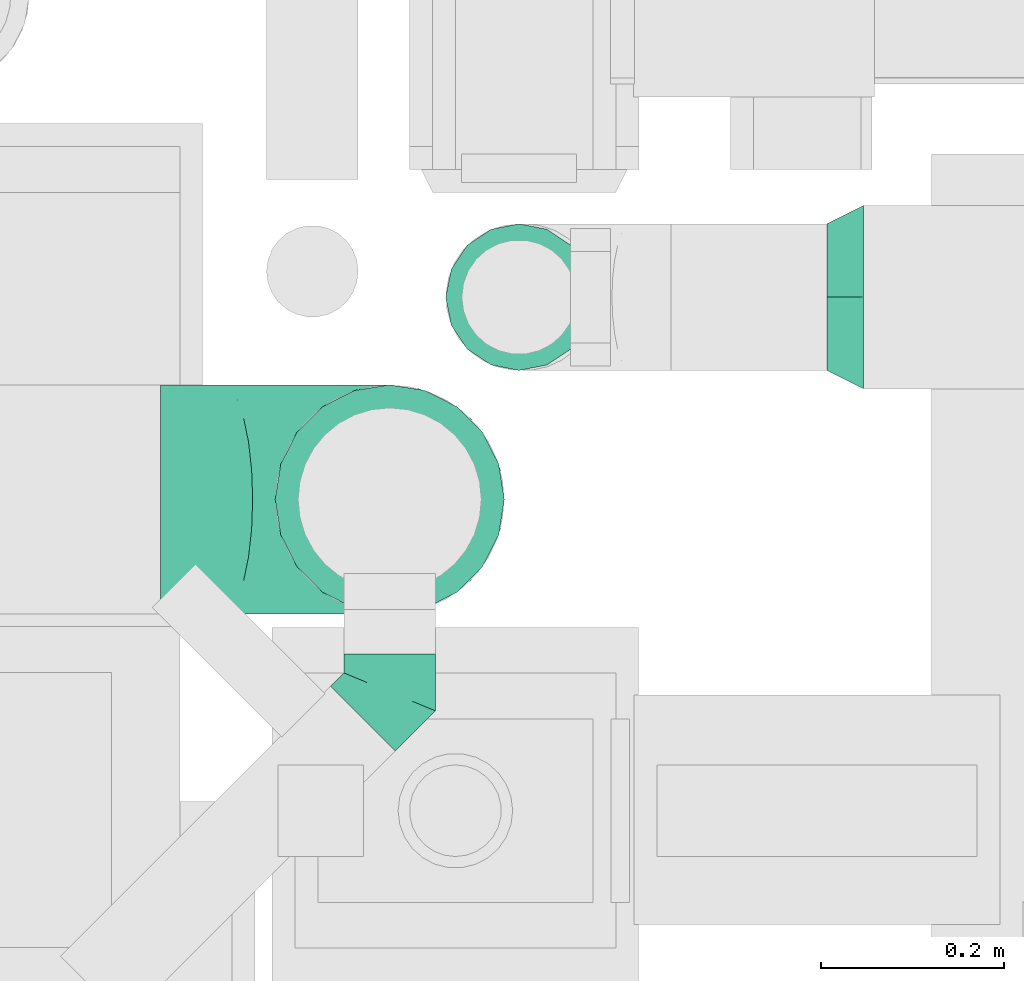
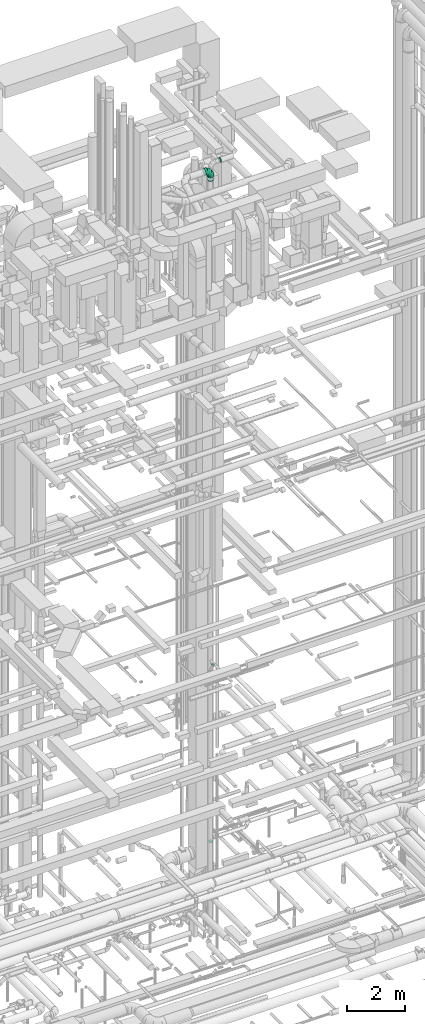
# One storey, part 238 of 337: 5 flow fittings.
"""IFC2X3 building model written with IfcOpenShell, lengths in millimetres."""

import ifcopenshell
import ifcopenshell.guid

model = None  # the IFC model being written
_history = None  # IfcOwnerHistory: only IFC2X3 demands one
_inside = {}  # id of a spatial element -> (the spatial element, [elements in it])
_under = {}  # id of a project, library or spatial element -> (it, [spatial elements below it])
_declared = {}  # id of a project -> (the project, [libraries it declares])
_typed = {}  # id of a type object -> (the type object, [elements of that type])
_made_of = {}  # id of a material, layer set ... -> (it, [elements and type objects made of it])


def new_model(schema):
    """Start an empty IFC model of exactly this schema.

    Asked for "IFC4X3", IfcOpenShell would pick the latest addendum, in which some entities
    have other attributes; the version numbers below select the first issue.
    IFC2X3 requires an IfcOwnerHistory on every rooted entity: one is made here for all.
    """
    global model, _history
    if schema == "IFC4X3":
        model = ifcopenshell.file(schema_version=(4, 3, 0, 0))
    else:
        model = ifcopenshell.file(schema=schema)
    _inside.clear()
    _under.clear()
    _declared.clear()
    _typed.clear()
    _made_of.clear()
    _history = None
    if model.schema == "IFC2X3":
        org = make("IfcOrganization", Name="unknown")
        user = make(
            "IfcPersonAndOrganization",
            ThePerson=make("IfcPerson", FamilyName="unknown"),
            TheOrganization=org,
        )
        app = make(
            "IfcApplication",
            ApplicationDeveloper=org,
            Version="unknown",
            ApplicationFullName="unknown",
            ApplicationIdentifier="unknown",
        )
        _history = make(
            "IfcOwnerHistory",
            OwningUser=user,
            OwningApplication=app,
            ChangeAction="ADDED",
            CreationDate=0,
        )
    return model


def make(cls, **values):
    """One entity of the class cls with the attributes given. An attribute that is None is left unset."""
    return model.create_entity(
        cls, **{name: value for name, value in values.items() if value is not None}
    )


def entity(cls, *values):
    """Any entity or typed value of the class cls, its attributes in the order of the schema. None: left unset."""
    e = model.create_entity(cls)
    for i, value in enumerate(values):
        if value is not None:
            e[i] = value
    return e


def rooted(cls, **values):
    """An entity with a GlobalId (a new one), such as an element, a storey or a relation."""
    return make(cls, GlobalId=ifcopenshell.guid.new(), OwnerHistory=_history, **values)


def si_unit(unit_type, name, prefix=None):
    """IfcSIUnit, for example si_unit("LENGTHUNIT", "METRE", prefix="MILLI")."""
    return make("IfcSIUnit", UnitType=unit_type, Prefix=prefix, Name=name)


def converted_unit(unit_type, name, factor, base, dimensions=None, offset=None):
    """IfcConversionBasedUnit, such as the inch: factor (a typed value) times the base unit."""
    return make(
        "IfcConversionBasedUnit"
        if offset is None
        else "IfcConversionBasedUnitWithOffset",
        ConversionOffset=offset,
        Dimensions=None
        if dimensions is None
        else entity("IfcDimensionalExponents", *dimensions),
        UnitType=unit_type,
        Name=name,
        ConversionFactor=make(
            "IfcMeasureWithUnit", ValueComponent=factor, UnitComponent=base
        ),
    )


def derived_unit(unit_type, elements):
    """IfcDerivedUnit: a product of units, each with its exponent."""
    return make(
        "IfcDerivedUnit",
        Elements=[
            make("IfcDerivedUnitElement", Unit=unit, Exponent=power)
            for unit, power in elements
        ],
        UnitType=unit_type,
    )


def assignment(units):
    """IfcUnitAssignment: the units of a project."""
    return None if units is None else make("IfcUnitAssignment", Units=units)


def point(xyz):
    """IfcCartesianPoint."""
    return None if xyz is None else make("IfcCartesianPoint", Coordinates=xyz)


def direction(xyz):
    """IfcDirection."""
    return None if xyz is None else make("IfcDirection", DirectionRatios=xyz)


def frame(location, z_axis=None, x_axis=None):
    """IfcAxis2Placement3D, a coordinate frame: its origin and axes. An axis left out is left unset."""
    return make(
        "IfcAxis2Placement3D",
        Location=point(location),
        Axis=direction(z_axis),
        RefDirection=direction(x_axis),
    )


def origin():
    """The frame at (0, 0, 0) with its axes left unset."""
    return frame((0.0, 0.0, 0.0))


def place(relative_to, where):
    """IfcLocalPlacement: puts the frame where relative to a parent placement (None: the world)."""
    return make(
        "IfcLocalPlacement", PlacementRelTo=relative_to, RelativePlacement=where
    )


def context(
    kind, dimensions, precision=None, world=None, true_north=None, identifier=None
):
    """IfcGeometricRepresentationContext, for example the 3D "Model" context."""
    return make(
        "IfcGeometricRepresentationContext",
        ContextIdentifier=identifier,
        ContextType=kind,
        CoordinateSpaceDimension=dimensions,
        Precision=precision,
        WorldCoordinateSystem=world,
        TrueNorth=true_north,
    )


def subcontext(parent, identifier, kind, view, scale=None):
    """IfcGeometricRepresentationSubContext, for example "Body" below "Model"."""
    return make(
        "IfcGeometricRepresentationSubContext",
        ContextIdentifier=identifier,
        ContextType=kind,
        ParentContext=parent,
        TargetScale=scale,
        TargetView=view,
    )


def project(units=None, contexts=None):
    """IfcProject with its units and contexts."""
    return rooted(
        "IfcProject",
        Name="project",
        RepresentationContexts=contexts,
        UnitsInContext=assignment(units),
    )


def spatial(cls, under=None, at=None, **own):
    """A site, building, storey or space (cls), placed at a placement, below another one or the project."""
    s = rooted(cls, ObjectPlacement=at, **own)
    if under is not None:
        _under.setdefault(under.id(), (under, []))[1].append(s)
    return s


def faces_of(points, faces, orient=None, outer=None):
    """IfcFace entities. A face is a list of loops; a loop is a list of indices into points, from 0.

    orient and outer hold one flag for each loop. By default every Orientation is true, the
    first loop of a face is its IfcFaceOuterBound and the others are IfcFaceBound.
    """
    made = []
    for i, loops in enumerate(faces):
        bounds = []
        for j, loop in enumerate(loops):
            is_outer = j == 0 if outer is None else outer[i][j]
            bounds.append(
                make(
                    "IfcFaceOuterBound" if is_outer else "IfcFaceBound",
                    Bound=make("IfcPolyLoop", Polygon=[points[k] for k in loop]),
                    Orientation=True if orient is None else orient[i][j],
                )
            )
        made.append(make("IfcFace", Bounds=bounds))
    return made


def faceted_brep(points, faces, orient=None, outer=None, voids=None):
    """IfcFacetedBrep: a solid bounded by flat faces; with voids (closed shells), ...WithVoids."""
    shared = [point(p) for p in points]
    hull = make("IfcClosedShell", CfsFaces=faces_of(shared, faces, orient, outer))
    if voids is None:
        return make("IfcFacetedBrep", Outer=hull)
    return make(
        "IfcFacetedBrepWithVoids",
        Outer=hull,
        Voids=[
            make(cls, CfsFaces=faces_of(shared, fs, o, b)) for cls, fs, o, b in voids
        ],
    )


def shape(context_of_items, identifier, shape_type, items):
    """IfcShapeRepresentation: the items that make up one representation, for example the "Body"."""
    return make(
        "IfcShapeRepresentation",
        ContextOfItems=context_of_items,
        RepresentationIdentifier=identifier,
        RepresentationType=shape_type,
        Items=items,
    )


def source(mapping_origin, context_of_items, identifier, shape_type, items):
    """IfcRepresentationMap: a shape defined once, which mapped items show again and again."""
    return make(
        "IfcRepresentationMap",
        MappingOrigin=mapping_origin,
        MappedRepresentation=shape(context_of_items, identifier, shape_type, items),
    )


def transform(
    local_origin,
    x_axis=None,
    y_axis=None,
    z_axis=None,
    scale=None,
    scale2=None,
    scale3=None,
    uniform=True,
):
    """IfcCartesianTransformationOperator3D, or its non-uniform kind. x_axis, y_axis, z_axis: its Axis1, 2, 3."""
    if uniform:
        return make(
            "IfcCartesianTransformationOperator3D",
            Axis1=direction(x_axis),
            Axis2=direction(y_axis),
            LocalOrigin=point(local_origin),
            Scale=scale,
            Axis3=direction(z_axis),
        )
    return make(
        "IfcCartesianTransformationOperator3DnonUniform",
        Axis1=direction(x_axis),
        Axis2=direction(y_axis),
        LocalOrigin=point(local_origin),
        Scale=scale,
        Axis3=direction(z_axis),
        Scale2=scale2,
        Scale3=scale3,
    )


def mapped(mapping_source, mapping_target):
    """IfcMappedItem: shows the shape of a source again, moved by a transform."""
    return make(
        "IfcMappedItem", MappingSource=mapping_source, MappingTarget=mapping_target
    )


def material(Name=None, Category=None):
    """IfcMaterial."""
    return make("IfcMaterial", Name=Name, Category=Category)


def made_of(thing, what):
    """Note that an element or type object is made of a material, layer set ...; save() writes the relation."""
    if what is not None:
        _made_of.setdefault(what.id(), (what, []))[1].append(thing)
    return thing


def type_object(cls, material=None, **own):
    """A type object (cls), such as IfcWallType, which elements share."""
    return made_of(rooted(cls, **own), material)


def type_shapes(of_type, sources):
    """Give a type object the sources (RepresentationMaps) that its elements show as mapped items."""
    of_type.RepresentationMaps = sources


def element(
    cls,
    number,
    at=None,
    inside=None,
    cuts=None,
    type_object=None,
    material=None,
    context=None,
    identifier="Body",
    shape_type=None,
    held_by="IfcProductDefinitionShape",
    body=None,
    shapes=None,
    **own,
):
    """One element of the class cls, such as IfcWall. Its Tag is "e" and its number.

    at: its placement. inside: the storey or other place that contains it. cuts: it is an
    opening in that element (IfcRelVoidsElement). A single representation is given by context,
    identifier, shape_type and body (its items); several are given by shapes. held_by: the class
    of the entity that holds the representations. save() writes the other relations.
    """
    e = rooted(cls, Tag="e%d" % number, ObjectPlacement=at, **own)
    if body is not None:
        shapes = [shape(context, identifier, shape_type, body)]
    if shapes is not None:
        e.Representation = make(held_by, Representations=shapes)
    if inside is not None:
        _inside.setdefault(inside.id(), (inside, []))[1].append(e)
    if cuts is not None:
        rooted(
            "IfcRelVoidsElement", RelatingBuildingElement=cuts, RelatedOpeningElement=e
        )
    if type_object is not None:
        _typed.setdefault(type_object.id(), (type_object, []))[1].append(e)
    return made_of(e, material)


def aggregate(whole, parts):
    """IfcRelAggregates: a whole, such as a stair, and the parts it consists of."""
    return rooted("IfcRelAggregates", RelatingObject=whole, RelatedObjects=parts)


def save(model, path):
    """Write the relations noted so far, then the file.

    IfcRelAggregates (storeys below a building ...), IfcRelContainedInSpatialStructure (elements
    in a storey), IfcRelDefinesByType, IfcRelAssociatesMaterial and IfcRelDeclares: one each for
    every whole, place, type object, material and project.
    """
    for whole, parts in _under.values():
        aggregate(whole, parts)
    for where, things in _inside.values():
        rooted(
            "IfcRelContainedInSpatialStructure",
            RelatedElements=things,
            RelatingStructure=where,
        )
    for kind, things in _typed.values():
        rooted("IfcRelDefinesByType", RelatedObjects=things, RelatingType=kind)
    for what, things in _made_of.values():
        rooted("IfcRelAssociatesMaterial", RelatedObjects=things, RelatingMaterial=what)
    for by, libraries in _declared.values():
        rooted("IfcRelDeclares", RelatingContext=by, RelatedDefinitions=libraries)
    model.write(path)


model = new_model("IFC2X3")

# Units and contexts
model_context = context("Model", 3, precision=0.01, world=origin(), true_north=direction((6.12303176911189e-17, 1.0)))
body_context = subcontext(model_context, "Body", "Model", "MODEL_VIEW")
ifc_project = project(units=[si_unit("LENGTHUNIT", "METRE", prefix="MILLI"), si_unit("AREAUNIT", "SQUARE_METRE"), si_unit("VOLUMEUNIT", "CUBIC_METRE"), converted_unit("PLANEANGLEUNIT", "DEGREE", entity("IfcRatioMeasure", 0.0174532925199433), si_unit("PLANEANGLEUNIT", "RADIAN"), dimensions=[0, 0, 0, 0, 0, 0, 0]), si_unit("MASSUNIT", "GRAM", prefix="KILO"), derived_unit("MASSDENSITYUNIT", [(si_unit("MASSUNIT", "GRAM", prefix="KILO"), 1), (si_unit("LENGTHUNIT", "METRE"), -3)]), derived_unit("MOMENTOFINERTIAUNIT", [(si_unit("LENGTHUNIT", "METRE"), 4)]), si_unit("TIMEUNIT", "SECOND"), si_unit("FREQUENCYUNIT", "HERTZ"), si_unit("THERMODYNAMICTEMPERATUREUNIT", "DEGREE_CELSIUS"), derived_unit("THERMALTRANSMITTANCEUNIT", [(si_unit("MASSUNIT", "GRAM", prefix="KILO"), 1), (si_unit("THERMODYNAMICTEMPERATUREUNIT", "KELVIN"), -1), (si_unit("TIMEUNIT", "SECOND"), -3)]), derived_unit("VOLUMETRICFLOWRATEUNIT", [(si_unit("LENGTHUNIT", "METRE"), 3), (si_unit("TIMEUNIT", "SECOND"), -1)]), derived_unit("MASSFLOWRATEUNIT", [(si_unit("MASSUNIT", "GRAM", prefix="KILO"), 1), (si_unit("TIMEUNIT", "SECOND"), -1)]), derived_unit("ROTATIONALFREQUENCYUNIT", [(si_unit("TIMEUNIT", "SECOND"), -1)]), si_unit("ELECTRICCURRENTUNIT", "AMPERE"), si_unit("ELECTRICVOLTAGEUNIT", "VOLT"), si_unit("POWERUNIT", "WATT"), si_unit("FORCEUNIT", "NEWTON", prefix="KILO"), si_unit("ILLUMINANCEUNIT", "LUX"), si_unit("LUMINOUSFLUXUNIT", "LUMEN"), si_unit("LUMINOUSINTENSITYUNIT", "CANDELA"), derived_unit("USERDEFINED", [(si_unit("MASSUNIT", "GRAM", prefix="KILO"), -1), (si_unit("LENGTHUNIT", "METRE"), -2), (si_unit("TIMEUNIT", "SECOND"), 3), (si_unit("LUMINOUSFLUXUNIT", "LUMEN"), 1)]), derived_unit("LINEARVELOCITYUNIT", [(si_unit("LENGTHUNIT", "METRE"), 1), (si_unit("TIMEUNIT", "SECOND"), -1)]), si_unit("PRESSUREUNIT", "PASCAL"), derived_unit("USERDEFINED", [(si_unit("LENGTHUNIT", "METRE"), -2), (si_unit("MASSUNIT", "GRAM", prefix="KILO"), 1), (si_unit("TIMEUNIT", "SECOND"), -2)]), derived_unit("LINEARFORCEUNIT", [(si_unit("MASSUNIT", "GRAM", prefix="KILO"), 1), (si_unit("LENGTHUNIT", "METRE"), 1), (si_unit("TIMEUNIT", "SECOND"), -2), (si_unit("LENGTHUNIT", "METRE"), -1)]), derived_unit("PLANARFORCEUNIT", [(si_unit("MASSUNIT", "GRAM", prefix="KILO"), 1), (si_unit("LENGTHUNIT", "METRE"), 1), (si_unit("TIMEUNIT", "SECOND"), -2), (si_unit("LENGTHUNIT", "METRE"), -2)])], contexts=[model_context])

# Site, building, storey
site_placement = place(None, origin())
site = spatial("IfcSite", under=ifc_project, at=site_placement, CompositionType="ELEMENT")
building_placement = place(site_placement, origin())
building = spatial("IfcBuilding", under=site, at=building_placement, CompositionType="ELEMENT")
storey_placement = place(building_placement, origin())
storey = spatial("IfcBuildingStorey", under=building, at=storey_placement, CompositionType="ELEMENT", Elevation=0.0)

# Flow fittings
ifc_material = material()
duct_fitting_type_1 = type_object("IfcDuctFittingType", PredefinedType="NOTDEFINED", material=ifc_material)
shared_shape_1 = source(origin(), body_context, "Body", "Brep", [
    faceted_brep([(40.0, -58.78, -80.9), (40.0, -30.9, -95.11), (40.0, 0.0, -100.0), (40.0, 30.9, -95.11), (40.0, 58.78, -80.9), (40.0, 80.9, -58.78), (40.0, 95.11, -30.9), (40.0, 100.0, 0.0), (40.0, 95.11, 30.9), (40.0, 80.9, 58.78), (40.0, 58.78, 80.9), (40.0, 30.9, 95.11), (40.0, 0.0, 100.0), (40.0, -30.9, 95.11), (40.0, -58.78, 80.9), (40.0, -80.9, 58.78), (40.0, -95.11, 30.9), (40.0, -100.0, 0.0), (40.0, -95.11, -30.9), (40.0, -80.9, -58.78), (0.0, -30.61, -73.91), (0.0, -43.59, -65.24), (0.0, -56.57, -56.57), (0.0, -65.24, -43.59), (0.0, -73.91, -30.61), (0.0, -76.96, -15.31), (0.0, -80.0, 0.0), (0.0, -76.96, 15.31), (0.0, -73.91, 30.61), (0.0, -65.24, 43.59), (0.0, -56.57, 56.57), (0.0, -43.59, 65.24), (0.0, -30.61, 73.91), (0.0, -15.31, 76.96), (0.0, 0.0, 80.0), (0.0, 15.31, 76.96), (0.0, 30.61, 73.91), (0.0, 43.59, 65.24), (0.0, 56.57, 56.57), (0.0, 65.24, 43.59), (0.0, 73.91, 30.61), (0.0, 76.96, 15.31), (0.0, 80.0, 0.0), (0.0, 76.96, -15.31), (0.0, 73.91, -30.61), (0.0, 65.24, -43.59), (0.0, 56.57, -56.57), (0.0, 43.59, -65.24), (0.0, 30.61, -73.91), (0.0, 15.31, -76.96), (0.0, 0.0, -80.0), (0.0, -15.31, -76.96)], [[[0, 1, 2, 3, 4, 5, 6, 7, 8, 9, 10, 11, 12, 13, 14, 15, 16, 17, 18, 19]], [[20, 21, 22, 23, 24, 25, 26, 27, 28, 29, 30, 31, 32, 33, 34, 35, 36, 37, 38, 39, 40, 41, 42, 43, 44, 45, 46, 47, 48, 49, 50, 51]], [[7, 41, 8]], [[40, 9, 8]], [[10, 38, 37, 36]], [[39, 38, 9, 40]], [[11, 36, 35]], [[34, 12, 35]], [[41, 40, 8]], [[10, 36, 11]], [[35, 12, 11]], [[41, 7, 42]], [[38, 10, 9]], [[12, 33, 13]], [[32, 14, 13]], [[15, 30, 29, 28]], [[31, 30, 14, 32]], [[16, 28, 27]], [[26, 17, 27]], [[33, 32, 13]], [[15, 28, 16]], [[27, 17, 16]], [[33, 12, 34]], [[30, 15, 14]], [[17, 25, 18]], [[24, 19, 18]], [[0, 22, 21, 20]], [[23, 22, 19, 24]], [[1, 20, 51]], [[50, 2, 51]], [[25, 24, 18]], [[0, 20, 1]], [[51, 2, 1]], [[25, 17, 26]], [[22, 0, 19]], [[2, 49, 3]], [[48, 4, 3]], [[5, 46, 45, 44]], [[47, 46, 4, 48]], [[6, 44, 43]], [[42, 7, 43]], [[49, 48, 3]], [[5, 44, 6]], [[43, 7, 6]], [[49, 2, 50]], [[46, 5, 4]]]),
])
type_shapes(duct_fitting_type_1, [shared_shape_1])
flow_fitting_1_placement = place(storey_placement, frame((59885.7, 11524.89, 31800.0)))
element("IfcFlowFitting", 1, at=flow_fitting_1_placement, inside=storey, type_object=duct_fitting_type_1, material=ifc_material, context=body_context, shape_type="MappedRepresentation", body=[
    mapped(shared_shape_1, transform((0.0, 0.0, 0.0), scale=1.0)),
])
duct_fitting_type_2 = type_object("IfcDuctFittingType", PredefinedType="NOTDEFINED", material=ifc_material)
shared_shape_2 = source(origin(), body_context, "Body", "Brep", [
    faceted_brep([(-250.0, 0.0, -125.0), (-250.0, -32.35, -120.74), (-250.0, -62.5, -108.25), (-250.0, -88.39, -88.39), (-250.0, -108.25, -62.5), (-250.0, -120.74, -32.35), (-250.0, -125.0, 0.0), (-250.0, -120.74, 32.35), (-250.0, -108.25, 62.5), (-250.0, -88.39, 88.39), (-250.0, -62.5, 108.25), (-250.0, -32.35, 120.74), (-250.0, 0.0, 125.0), (-250.0, 32.35, 120.74), (-250.0, 62.5, 108.25), (-250.0, 88.39, 88.39), (-250.0, 108.25, 62.5), (-250.0, 120.74, 32.35), (-250.0, 125.0, 0.0), (-250.0, 120.74, -32.35), (-250.0, 108.25, -62.5), (-250.0, 88.39, -88.39), (-250.0, 62.5, -108.25), (-250.0, 32.35, -120.74), (-191.68, 32.35, 120.74), (-199.76, 62.5, 108.25), (-183.01, 0.0, 125.0), (-206.7, 88.39, 88.39), (-215.37, 120.74, 32.35), (-216.51, 125.0, 0.0), (-212.02, 108.25, 62.5), (-212.02, 108.25, -62.5), (-206.7, 88.39, -88.39), (-215.37, 120.74, -32.35), (-191.68, 32.35, -120.74), (-183.01, 0.0, -125.0), (-199.76, 62.5, -108.25), (-174.34, -32.35, -120.74), (-166.27, -62.5, -108.25), (-159.33, -88.39, -88.39), (-154.01, -108.25, -62.5), (-150.66, -120.74, -32.35), (-149.52, -125.0, 0.0), (-150.66, -120.74, 32.35), (-154.01, -108.25, 62.5), (-159.33, -88.39, 88.39), (-166.27, -62.5, 108.25), (-174.34, -32.35, 120.74), (-90.67, 90.67, 120.74), (-112.74, 112.74, 108.25), (-66.99, 66.99, 125.0), (-131.69, 131.69, 88.39), (-146.23, 146.23, 62.5), (-155.38, 155.38, 32.35), (-158.49, 158.49, 0.0), (-155.38, 155.38, -32.35), (-146.23, 146.23, -62.5), (-131.69, 131.69, -88.39), (-90.67, 90.67, -120.74), (-66.99, 66.99, -125.0), (-112.74, 112.74, -108.25), (-43.3, 43.3, -120.74), (-21.23, 21.23, -108.25), (-2.28, 2.28, -88.39), (12.26, -12.26, -62.5), (21.4, -21.4, -32.35), (24.52, -24.52, 0.0), (21.4, -21.4, 32.35), (12.26, -12.26, 62.5), (-2.28, 2.28, 88.39), (-21.23, 21.23, 108.25), (-43.3, 43.3, 120.74), (-32.35, 191.68, 120.74), (-62.5, 199.76, 108.25), (0.0, 183.01, 125.0), (-88.39, 206.7, 88.39), (-108.25, 212.02, 62.5), (-120.74, 215.37, 32.35), (-125.0, 216.51, 0.0), (-120.74, 215.37, -32.35), (-108.25, 212.02, -62.5), (-88.39, 206.7, -88.39), (-32.35, 191.68, -120.74), (0.0, 183.01, -125.0), (-62.5, 199.76, -108.25), (32.35, 174.34, -120.74), (62.5, 166.27, -108.25), (88.39, 159.33, -88.39), (108.25, 154.01, -62.5), (120.74, 150.66, -32.35), (125.0, 149.52, 0.0), (120.74, 150.66, 32.35), (108.25, 154.01, 62.5), (88.39, 159.33, 88.39), (62.5, 166.27, 108.25), (32.35, 174.34, 120.74), (-32.35, 250.0, -120.74), (-62.5, 250.0, -108.25), (-88.39, 250.0, -88.39), (-108.25, 250.0, -62.5), (-120.74, 250.0, -32.35), (-125.0, 250.0, 0.0), (-120.74, 250.0, 32.35), (-108.25, 250.0, 62.5), (-88.39, 250.0, 88.39), (-62.5, 250.0, 108.25), (-32.35, 250.0, 120.74), (0.0, 250.0, 125.0), (32.35, 250.0, 120.74), (62.5, 250.0, 108.25), (88.39, 250.0, 88.39), (108.25, 250.0, 62.5), (120.74, 250.0, 32.35), (125.0, 250.0, 0.0), (120.74, 250.0, -32.35), (108.25, 250.0, -62.5), (88.39, 250.0, -88.39), (62.5, 250.0, -108.25), (32.35, 250.0, -120.74), (0.0, 250.0, -125.0)], [[[0, 1, 2, 3, 4, 5, 6, 7, 8, 9, 10, 11, 12, 13, 14, 15, 16, 17, 18, 19, 20, 21, 22, 23]], [[24, 25, 14, 13]], [[26, 24, 13, 12]], [[14, 25, 27, 15]], [[28, 29, 18, 17]], [[30, 28, 17, 16]], [[15, 27, 30, 16]], [[20, 31, 32, 21]], [[33, 31, 20, 19]], [[18, 29, 33, 19]], [[34, 35, 0, 23]], [[36, 34, 23, 22]], [[21, 32, 36, 22]], [[1, 0, 35, 37]], [[2, 1, 37, 38]], [[38, 39, 3, 2]], [[5, 4, 40, 41]], [[6, 5, 41, 42]], [[39, 40, 4, 3]], [[6, 42, 43, 7]], [[7, 43, 44, 8]], [[8, 44, 45, 9]], [[9, 45, 46, 10]], [[10, 46, 47, 11]], [[26, 12, 11, 47]], [[48, 49, 25, 24]], [[50, 48, 24, 26]], [[27, 25, 49, 51]], [[52, 53, 28, 30]], [[51, 52, 30, 27]], [[29, 28, 53, 54]], [[55, 56, 31, 33]], [[54, 55, 33, 29]], [[32, 31, 56, 57]], [[58, 59, 35, 34]], [[60, 58, 34, 36]], [[57, 60, 36, 32]], [[37, 35, 59, 61]], [[38, 37, 61, 62]], [[39, 38, 62, 63]], [[41, 40, 64, 65]], [[42, 41, 65, 66]], [[63, 64, 40, 39]], [[43, 42, 66, 67]], [[44, 43, 67, 68]], [[68, 69, 45, 44]], [[46, 45, 69, 70]], [[47, 46, 70, 71]], [[26, 47, 71, 50]], [[72, 73, 49, 48]], [[74, 72, 48, 50]], [[51, 49, 73, 75]], [[76, 77, 53, 52]], [[75, 76, 52, 51]], [[54, 53, 77, 78]], [[79, 80, 56, 55]], [[78, 79, 55, 54]], [[57, 56, 80, 81]], [[82, 83, 59, 58]], [[84, 82, 58, 60]], [[81, 84, 60, 57]], [[61, 59, 83, 85]], [[62, 61, 85, 86]], [[63, 62, 86, 87]], [[65, 64, 88, 89]], [[66, 65, 89, 90]], [[87, 88, 64, 63]], [[67, 66, 90, 91]], [[68, 67, 91, 92]], [[92, 93, 69, 68]], [[70, 69, 93, 94]], [[71, 70, 94, 95]], [[50, 71, 95, 74]], [[96, 97, 98, 99, 100, 101, 102, 103, 104, 105, 106, 107, 108, 109, 110, 111, 112, 113, 114, 115, 116, 117, 118, 119]], [[72, 74, 107, 106]], [[73, 72, 106, 105]], [[75, 73, 105, 104]], [[77, 76, 103, 102]], [[78, 77, 102, 101]], [[75, 104, 103, 76]], [[78, 101, 100, 79]], [[79, 100, 99, 80]], [[80, 99, 98, 81]], [[84, 97, 96, 82]], [[82, 96, 119, 83]], [[84, 81, 98, 97]], [[83, 119, 118, 85]], [[85, 118, 117, 86]], [[116, 87, 86, 117]], [[88, 115, 114, 89]], [[89, 114, 113, 90]], [[115, 88, 87, 116]], [[91, 90, 113, 112]], [[92, 91, 112, 111]], [[111, 110, 93, 92]], [[95, 94, 109, 108]], [[74, 95, 108, 107]], [[110, 109, 94, 93]]]),
])
type_shapes(duct_fitting_type_2, [shared_shape_2])
flow_fitting_2_placement = place(storey_placement, frame((59408.94, 11304.18, 31699.6), z_axis=(0.0, 1.0, 0.0), x_axis=(1.0, 0.0, 0.0)))
element("IfcFlowFitting", 2, at=flow_fitting_2_placement, inside=storey, type_object=duct_fitting_type_2, material=ifc_material, context=body_context, shape_type="MappedRepresentation", body=[
    mapped(shared_shape_2, transform((0.0, 0.0, 0.0), scale=1.0)),
])
duct_fitting_type_3 = type_object("IfcDuctFittingType", PredefinedType="NOTDEFINED", material=ifc_material)
shared_shape_3 = source(origin(), body_context, "Body", "Brep", [
    faceted_brep([(35.0, -57.74, 23.92), (35.0, -60.12, 11.96), (35.0, -62.5, 0.0), (35.0, -60.12, -11.96), (35.0, -57.74, -23.92), (35.0, -50.97, -34.06), (35.0, -44.19, -44.19), (35.0, -34.06, -50.97), (35.0, -23.92, -57.74), (35.0, -11.96, -60.12), (35.0, 0.0, -62.5), (35.0, 11.96, -60.12), (35.0, 23.92, -57.74), (35.0, 34.06, -50.97), (35.0, 44.19, -44.19), (35.0, 50.97, -34.06), (35.0, 57.74, -23.92), (35.0, 60.12, -11.96), (35.0, 62.5, 0.0), (35.0, 60.12, 11.96), (35.0, 57.74, 23.92), (35.0, 50.97, 34.06), (35.0, 44.19, 44.19), (35.0, 34.06, 50.97), (35.0, 23.92, 57.74), (35.0, 11.96, 60.12), (35.0, 0.0, 62.5), (35.0, -11.96, 60.12), (35.0, -23.92, 57.74), (35.0, -34.06, 50.97), (35.0, -44.19, 44.19), (35.0, -50.97, 34.06), (0.0, -80.0, 0.0), (0.0, -77.45, 12.81), (0.0, -73.91, 30.61), (0.0, -65.24, 43.59), (0.0, -56.57, 56.57), (0.0, -43.59, 65.24), (0.0, -30.61, 73.91), (0.0, -12.81, 77.45), (0.0, 0.0, 80.0), (0.0, 12.81, 77.45), (0.0, 30.61, 73.91), (0.0, 43.59, 65.24), (0.0, 56.57, 56.57), (0.0, 65.24, 43.59), (0.0, 73.91, 30.61), (0.0, 77.45, 12.81), (0.0, 80.0, 0.0), (0.0, 77.45, -12.81), (0.0, 73.91, -30.61), (0.0, 65.24, -43.59), (0.0, 56.57, -56.57), (0.0, 43.59, -65.24), (0.0, 30.61, -73.91), (0.0, 12.81, -77.45), (0.0, 0.0, -80.0), (0.0, -12.81, -77.45), (0.0, -30.61, -73.91), (0.0, -43.59, -65.24), (0.0, -56.57, -56.57), (0.0, -65.24, -43.59), (0.0, -73.91, -30.61), (0.0, -77.45, -12.81)], [[[0, 1, 2, 3, 4, 5, 6, 7, 8, 9, 10, 11, 12, 13, 14, 15, 16, 17, 18, 19, 20, 21, 22, 23, 24, 25, 26, 27, 28, 29, 30, 31]], [[32, 33, 34, 35, 36, 37, 38, 39, 40, 41, 42, 43, 44, 45, 46, 47, 48, 49, 50, 51, 52, 53, 54, 55, 56, 57, 58, 59, 60, 61, 62, 63]], [[24, 23, 22, 44, 43, 42]], [[20, 46, 45, 44, 22, 21]], [[42, 41, 40, 26, 25, 24]], [[47, 46, 20, 19, 18, 48]], [[0, 31, 30, 36, 35, 34]], [[28, 38, 37, 36, 30, 29]], [[34, 33, 32, 2, 1, 0]], [[39, 38, 28, 27, 26, 40]], [[8, 7, 6, 60, 59, 58]], [[4, 62, 61, 60, 6, 5]], [[58, 57, 56, 10, 9, 8]], [[63, 62, 4, 3, 2, 32]], [[16, 15, 14, 52, 51, 50]], [[12, 54, 53, 52, 14, 13]], [[50, 49, 48, 18, 17, 16]], [[55, 54, 12, 11, 10, 56]]]),
])
type_shapes(duct_fitting_type_3, [shared_shape_3])
flow_fitting_3_placement = place(storey_placement, frame((59549.99, 11524.89, 3330.0), z_axis=(-0.99999997990083, 0.0, 0.000200495235506282), x_axis=(-0.000200495235506282, 0.0, -0.99999997990083)))
element("IfcFlowFitting", 3, at=flow_fitting_3_placement, inside=storey, type_object=duct_fitting_type_3, material=ifc_material, context=body_context, shape_type="MappedRepresentation", body=[
    mapped(shared_shape_3, transform((0.0, 0.0, 0.0), scale=1.0)),
])
duct_fitting_type_4 = type_object("IfcDuctFittingType", PredefinedType="NOTDEFINED", material=ifc_material)
shared_shape_4 = source(origin(), body_context, "Body", "Brep", [
    faceted_brep([(-41.42, 0.0, -50.0), (-41.42, -12.94, -48.3), (-41.42, -25.0, -43.3), (-41.42, -35.36, -35.36), (-41.42, -43.3, -25.0), (-41.42, -48.3, -12.94), (-41.42, -50.0, 0.0), (-41.42, -48.3, 12.94), (-41.42, -43.3, 25.0), (-41.42, -35.36, 35.36), (-41.42, -25.0, 43.3), (-41.42, -12.94, 48.3), (-41.42, 0.0, 50.0), (-41.42, 12.94, 48.3), (-41.42, 25.0, 43.3), (-41.42, 35.36, 35.36), (-41.42, 43.3, 25.0), (-41.42, 48.3, 12.94), (-41.42, 50.0, 0.0), (-41.42, 48.3, -12.94), (-41.42, 43.3, -25.0), (-41.42, 35.36, -35.36), (-41.42, 25.0, -43.3), (-41.42, 12.94, -48.3), (-5.36, 12.94, 48.3), (-10.36, 25.0, 43.3), (0.0, 0.0, 50.0), (-14.64, 35.36, 35.36), (-20.0, 48.3, 12.94), (-20.71, 50.0, 0.0), (-17.94, 43.3, 25.0), (-17.94, 43.3, -25.0), (-14.64, 35.36, -35.36), (-20.0, 48.3, -12.94), (-5.36, 12.94, -48.3), (0.0, 0.0, -50.0), (-10.36, 25.0, -43.3), (5.36, -12.94, -48.3), (10.36, -25.0, -43.3), (14.64, -35.36, -35.36), (17.94, -43.3, -25.0), (20.0, -48.3, -12.94), (20.71, -50.0, 0.0), (20.0, -48.3, 12.94), (17.94, -43.3, 25.0), (14.64, -35.36, 35.36), (10.36, -25.0, 43.3), (5.36, -12.94, 48.3), (29.29, 29.29, 50.0), (20.14, 38.44, 48.3), (11.61, 46.97, 43.3), (4.29, 54.29, 35.36), (-1.33, 59.91, 25.0), (-4.86, 63.44, 12.94), (-6.07, 64.64, 0.0), (-4.86, 63.44, -12.94), (-1.33, 59.91, -25.0), (4.29, 54.29, -35.36), (11.61, 46.97, -43.3), (20.14, 38.44, -48.3), (29.29, 29.29, -50.0), (38.44, 20.14, -48.3), (46.97, 11.61, -43.3), (54.29, 4.29, -35.36), (59.91, -1.33, -25.0), (63.44, -4.86, -12.94), (64.64, -6.07, 0.0), (63.44, -4.86, 12.94), (59.91, -1.33, 25.0), (54.29, 4.29, 35.36), (46.97, 11.61, 43.3), (38.44, 20.14, 48.3)], [[[0, 1, 2, 3, 4, 5, 6, 7, 8, 9, 10, 11, 12, 13, 14, 15, 16, 17, 18, 19, 20, 21, 22, 23]], [[24, 25, 14, 13]], [[26, 24, 13, 12]], [[14, 25, 27, 15]], [[28, 29, 18, 17]], [[30, 28, 17, 16]], [[16, 15, 27, 30]], [[20, 31, 32, 21]], [[33, 31, 20, 19]], [[18, 29, 33, 19]], [[34, 35, 0, 23]], [[36, 34, 23, 22]], [[32, 36, 22, 21]], [[1, 0, 35, 37]], [[2, 1, 37, 38]], [[38, 39, 3, 2]], [[5, 4, 40, 41]], [[6, 5, 41, 42]], [[39, 40, 4, 3]], [[6, 42, 43, 7]], [[7, 43, 44, 8]], [[8, 44, 45, 9]], [[9, 45, 46, 10]], [[10, 46, 47, 11]], [[26, 12, 11, 47]], [[24, 26, 48, 49]], [[25, 24, 49, 50]], [[27, 25, 50, 51]], [[28, 30, 52, 53]], [[29, 28, 53, 54]], [[27, 51, 52, 30]], [[29, 54, 55, 33]], [[33, 55, 56, 31]], [[31, 56, 57, 32]], [[36, 58, 59, 34]], [[34, 59, 60, 35]], [[36, 32, 57, 58]], [[61, 62, 38, 37]], [[60, 61, 37, 35]], [[63, 39, 38, 62]], [[40, 64, 65, 41]], [[41, 65, 66, 42]], [[64, 40, 39, 63]], [[43, 42, 66, 67]], [[44, 43, 67, 68]], [[68, 69, 45, 44]], [[47, 46, 70, 71]], [[26, 47, 71, 48]], [[69, 70, 46, 45]], [[59, 58, 57, 56, 55, 54, 53, 52, 51, 50, 49, 48, 71, 70, 69, 68, 67, 66, 65, 64, 63, 62, 61, 60]]]),
])
type_shapes(duct_fitting_type_4, [shared_shape_4])
flow_fitting_4_placement = place(storey_placement, frame((59408.94, 11094.22, 11050.0), z_axis=(0.0, 0.0, 1.0), x_axis=(0.707106781186579, 0.707106781186516, 0.0)))
element("IfcFlowFitting", 4, at=flow_fitting_4_placement, inside=storey, type_object=duct_fitting_type_4, material=ifc_material, context=body_context, shape_type="MappedRepresentation", body=[
    mapped(shared_shape_4, transform((0.0, 0.0, 0.0), scale=1.0)),
])
duct_fitting_type_5 = type_object("IfcDuctFittingType", PredefinedType="NOTDEFINED", material=ifc_material)
shared_shape_5 = source(origin(), body_context, "Body", "Brep", [
    faceted_brep([(50.0, 80.9, -58.78), (50.0, 95.11, -30.9), (50.0, 100.0, 0.0), (50.0, 95.11, 30.9), (50.0, 80.9, 58.78), (50.0, 58.78, 80.9), (50.0, 30.9, 95.11), (50.0, 0.0, 100.0), (50.0, -30.9, 95.11), (50.0, -58.78, 80.9), (50.0, -80.9, 58.78), (50.0, -95.11, 30.9), (50.0, -100.0, 0.0), (50.0, -95.11, -30.9), (50.0, -80.9, -58.78), (50.0, -58.78, -80.9), (50.0, -30.9, -95.11), (50.0, 0.0, -100.0), (50.0, 30.9, -95.11), (50.0, 58.78, -80.9), (0.0, -125.0, 0.0), (0.0, -118.88, 38.63), (0.0, -101.13, 73.47), (0.0, -73.47, 101.13), (0.0, -38.63, 118.88), (0.0, 0.0, 125.0), (0.0, 38.63, 118.88), (0.0, 73.47, 101.13), (0.0, 101.13, 73.47), (0.0, 118.88, 38.63), (0.0, 125.0, 0.0), (0.0, 118.88, -38.63), (0.0, 101.13, -73.47), (0.0, 73.47, -101.13), (0.0, 38.63, -118.88), (0.0, 0.0, -125.0), (0.0, -38.63, -118.88), (0.0, -73.47, -101.13), (0.0, -101.13, -73.47), (0.0, -118.88, -38.63)], [[[0, 1, 2, 3, 4, 5, 6, 7, 8, 9, 10, 11, 12, 13, 14, 15, 16, 17, 18, 19]], [[20, 21, 22, 23, 24, 25, 26, 27, 28, 29, 30, 31, 32, 33, 34, 35, 36, 37, 38, 39]], [[26, 25, 7, 6]], [[27, 26, 6, 5]], [[5, 4, 28, 27]], [[3, 2, 30, 29]], [[4, 3, 29, 28]], [[21, 20, 12, 11]], [[22, 21, 11, 10]], [[10, 9, 23, 22]], [[8, 7, 25, 24]], [[9, 8, 24, 23]], [[36, 35, 17, 16]], [[37, 36, 16, 15]], [[15, 14, 38, 37]], [[13, 12, 20, 39]], [[14, 13, 39, 38]], [[31, 30, 2, 1]], [[32, 31, 1, 0]], [[0, 19, 33, 32]], [[18, 17, 35, 34]], [[19, 18, 34, 33]]]),
])
type_shapes(duct_fitting_type_5, [shared_shape_5])
flow_fitting_5_placement = place(storey_placement, frame((59408.94, 11304.18, 31319.6), z_axis=(1.0, 0.0, 0.0), x_axis=(0.0, 0.0, -1.0)))
element("IfcFlowFitting", 5, at=flow_fitting_5_placement, inside=storey, type_object=duct_fitting_type_5, material=ifc_material, context=body_context, shape_type="MappedRepresentation", body=[
    mapped(shared_shape_5, transform((0.0, 0.0, 0.0), scale=1.0)),
])

save(model, "model.ifc")
